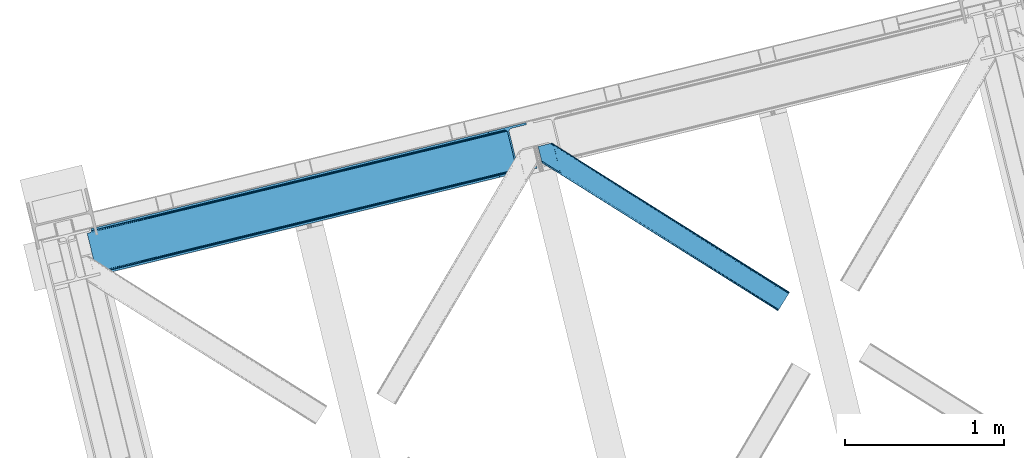
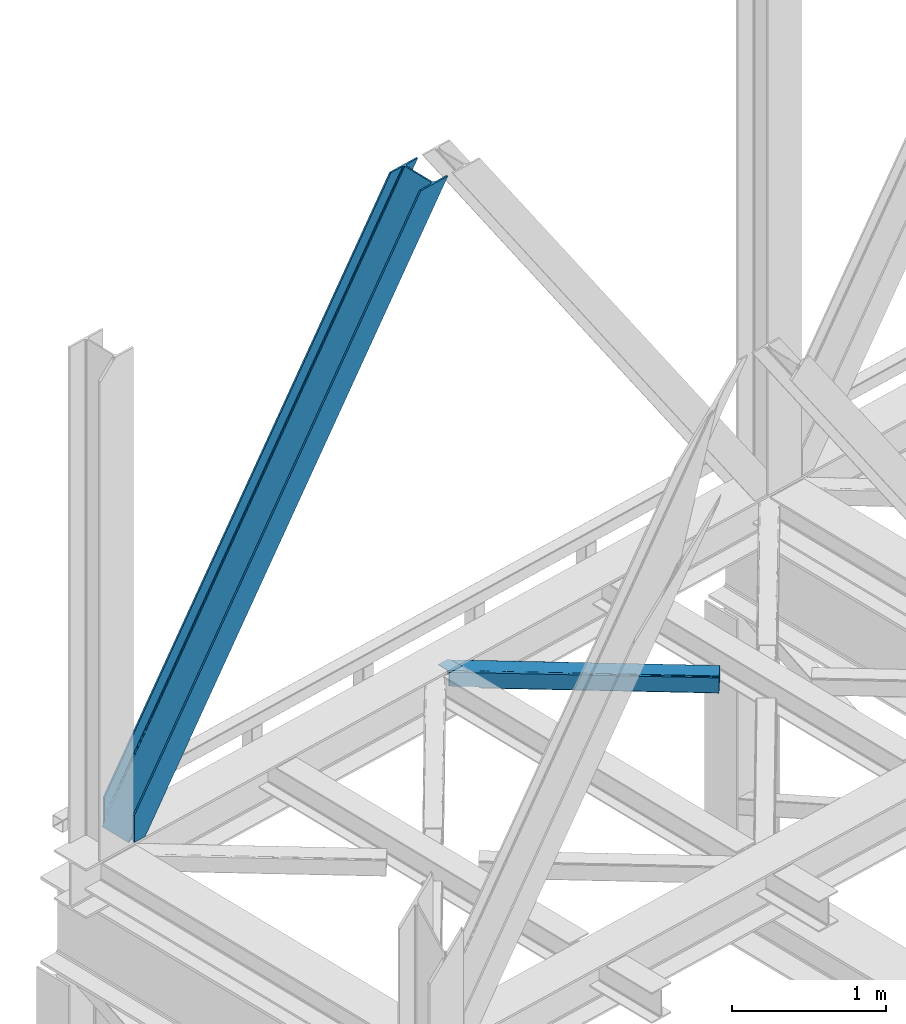
# One storey, part 26 of 93: 2 members.
"""IFC4 building model written with IfcOpenShell, lengths in millimetres."""

from ifc_helpers import new_model, entity, si_unit, converted_unit, derived_unit, direction, frame, origin, place, context, subcontext, project, spatial, triangles, type_object, element, save


model = new_model("IFC4")

# Units and contexts
model_context = context("Model", 3, precision=0.01, world=origin(), true_north=direction((6.12303176911189e-17, 1.0)))
plan_context = context("Plan", 3, precision=0.01, world=origin(), true_north=direction((6.12303176911189e-17, 1.0)))
body_context = subcontext(model_context, "Body", "Model", "MODEL_VIEW")
ifc_project = project(units=[si_unit("LENGTHUNIT", "METRE", prefix="MILLI"), si_unit("AREAUNIT", "SQUARE_METRE"), si_unit("VOLUMEUNIT", "CUBIC_METRE"), converted_unit("PLANEANGLEUNIT", "DEGREE", entity("IfcRatioMeasure", 0.0174532925199433), si_unit("PLANEANGLEUNIT", "RADIAN"), dimensions=[0, 0, 0, 0, 0, 0, 0]), si_unit("MASSUNIT", "GRAM", prefix="KILO"), derived_unit("MASSDENSITYUNIT", [(si_unit("MASSUNIT", "GRAM", prefix="KILO"), 1), (si_unit("LENGTHUNIT", "METRE"), -3)]), derived_unit("MOMENTOFINERTIAUNIT", [(si_unit("LENGTHUNIT", "METRE"), 4)]), si_unit("TIMEUNIT", "SECOND"), si_unit("FREQUENCYUNIT", "HERTZ"), si_unit("THERMODYNAMICTEMPERATUREUNIT", "DEGREE_CELSIUS"), derived_unit("THERMALTRANSMITTANCEUNIT", [(si_unit("MASSUNIT", "GRAM", prefix="KILO"), 1), (si_unit("THERMODYNAMICTEMPERATUREUNIT", "KELVIN"), -1), (si_unit("TIMEUNIT", "SECOND"), -3)]), derived_unit("VOLUMETRICFLOWRATEUNIT", [(si_unit("LENGTHUNIT", "METRE"), 3), (si_unit("TIMEUNIT", "SECOND"), -1)]), derived_unit("MASSFLOWRATEUNIT", [(si_unit("MASSUNIT", "GRAM", prefix="KILO"), 1), (si_unit("TIMEUNIT", "SECOND"), -1)]), derived_unit("ROTATIONALFREQUENCYUNIT", [(si_unit("TIMEUNIT", "SECOND"), -1)]), si_unit("ELECTRICCURRENTUNIT", "AMPERE"), si_unit("ELECTRICVOLTAGEUNIT", "VOLT"), si_unit("POWERUNIT", "WATT"), si_unit("FORCEUNIT", "NEWTON", prefix="KILO"), si_unit("ILLUMINANCEUNIT", "LUX"), si_unit("LUMINOUSFLUXUNIT", "LUMEN"), si_unit("LUMINOUSINTENSITYUNIT", "CANDELA"), derived_unit("USERDEFINED", [(si_unit("MASSUNIT", "GRAM", prefix="KILO"), -1), (si_unit("LENGTHUNIT", "METRE"), -2), (si_unit("TIMEUNIT", "SECOND"), 3), (si_unit("LUMINOUSFLUXUNIT", "LUMEN"), 1)]), derived_unit("LINEARVELOCITYUNIT", [(si_unit("LENGTHUNIT", "METRE"), 1), (si_unit("TIMEUNIT", "SECOND"), -1)]), si_unit("PRESSUREUNIT", "PASCAL"), derived_unit("USERDEFINED", [(si_unit("LENGTHUNIT", "METRE"), -2), (si_unit("MASSUNIT", "GRAM", prefix="KILO"), 1), (si_unit("TIMEUNIT", "SECOND"), -2)]), derived_unit("LINEARFORCEUNIT", [(si_unit("MASSUNIT", "GRAM", prefix="KILO"), 1), (si_unit("LENGTHUNIT", "METRE"), 1), (si_unit("TIMEUNIT", "SECOND"), -2), (si_unit("LENGTHUNIT", "METRE"), -1)]), derived_unit("PLANARFORCEUNIT", [(si_unit("MASSUNIT", "GRAM", prefix="KILO"), 1), (si_unit("LENGTHUNIT", "METRE"), 1), (si_unit("TIMEUNIT", "SECOND"), -2), (si_unit("LENGTHUNIT", "METRE"), -2)])], contexts=[model_context, plan_context])

# Site, building, storey
site_placement = place(None, origin())
site = spatial("IfcSite", under=ifc_project, at=site_placement, CompositionType="ELEMENT")
building_placement = place(site_placement, origin())
building = spatial("IfcBuilding", under=site, at=building_placement, CompositionType="ELEMENT")
storey_placement = place(building_placement, frame((0.0, 0.0, 15900.0)))
storey = spatial("IfcBuildingStorey", under=building, at=storey_placement, CompositionType="ELEMENT", Elevation=15900.0)

# Members
member_type_1 = type_object("IfcMemberType", PredefinedType="BRACE")
member_1_placement = place(storey_placement, frame((-60913.7237548828, 5815.15086364746, 3684.99990234375)))
element("IfcMember", 1, at=member_1_placement, inside=storey, type_object=member_type_1, ObjectType="Steel Vertical Brace", PredefinedType="BRACE", context=body_context, shape_type="Tessellation", body=[
    triangles([(58.5685180664004, 23.1980026245119, 0.0), (60.4660766601519, 15.4258026123052, 0.0), (59.1080200195283, 16.2391250610353, 0.781347656247817), (58.9684936523408, 15.0607086181644, 1.0697021484375), (78.1673217773423, 19.7406555175785, 8.06229858398365), (78.1673217773423, 19.7406555175785, 29.5563354492188), (72.7350952148408, 18.4163177490236, 0.0), (500.415966796871, 117.80269317627, 660.427130126951), (82.4554321289033, 19.9237838745121, 36.4024291992173), (86.4830932617188, 18.4523620605469, 44.3670593261704), (502.150744628903, 124.235440063477, 658.201684570311), (88.0643920898438, 17.2873168945316, 48.5435485839844), (2700.97932128906, 660.223072814942, 3921.00020141601), (2700.96536865235, 667.310430908204, 3921.00020141601), (2273.77749023437, 563.178996276855, 3287.10633544922), (2274.31699218749, 556.220118713379, 3287.88535766601), (2697.74696044921, 653.425231933594, 3921.00020141601), (2272.58686523437, 549.787371826172, 3290.11080322265), (2691.76593017578, 647.951147460938, 3921.00020141601), (2268.84755859375, 544.859765625, 3293.43850708008), (2683.94780273437, 644.634489440919, 3921.00020141601), (2263.67113037109, 542.188417053223, 3297.36384887695), (491.5048828125, 110.20373840332, 667.68017578125), (496.68131103515, 112.875086975097, 663.754833984374), (91.1758300781221, 12.6195785522459, 73.6396911621086), (90.6456298828125, 13.899732971192, 61.2474243164033), (89.48291015625, 15.4258026123052, 55.5245178222649), (501.611242675775, 131.194317626953, 657.42033691406), (945.193469238278, 232.231755065918, 1315.62202148437), (944.65396728515, 239.190632629395, 1314.84299926758), (1388.23154296874, 340.227488708496, 1973.04468383789), (1387.69669189453, 347.186366271972, 1972.26333618164), (1831.27426757812, 448.223803710937, 2630.46502075195), (1830.7394165039, 455.182681274414, 2629.6836730957), (943.458691406246, 225.799008178711, 1317.84746704101), (1386.50141601562, 333.795323181153, 1975.26780395508), (1829.544140625, 441.79105682373, 2632.68814086914), (939.724035644525, 220.871401977539, 1321.17517089844), (1382.762109375, 328.86771697998, 1978.5955078125), (1825.80483398437, 436.864031982422, 2636.01817016601), (934.547607421875, 218.200053405762, 1325.10051269531), (1377.59033203125, 326.196368408203, 1982.52317504883), (1820.63305664063, 434.192102050782, 2639.94351196289), (91.1758300781221, 12.6195785522459, 210.054620361327), (2592.01387939453, 622.225392150879, 3921.00020141601), (1332.51401367187, 573.558013916016, 1972.26333618164), (2645.78734130859, 893.682078552246, 3921.00020141601), (2218.59946289062, 789.550643920898, 3287.10633544922), (1775.55673828124, 681.554328918457, 2629.6836730957), (889.471289062494, 465.562280273438, 1314.84299926758), (446.433215332028, 357.565965270996, 657.42033691406), (3.39049072265334, 249.569650268555, 0.0), (86.4830932617188, 18.4523620605469, 15.6757873535134), (82.4554321289033, 19.9237838745121, 13.352673339843), (84.3483398437456, 19.4546264648443, 14.892114257811), (88.0643920898438, 17.2873168945316, 15.1293090820291), (91.4595336914063, 11.6585906982427, 0.0), (90.6456298828125, 13.899732971192, 7.3414123535149), (89.6456909179688, 15.5502136230471, 12.4201721191384), (91.4595336914063, 11.6585906982427, 210.119732666015), (91.1153686523394, 12.7904983520511, 0.0), (2595.09276123047, 609.595349121094, 3921.00020141601), (94.3012207031206, 0.0, 210.119732666015), (94.3012207031206, 0.0, 0.0), (189.179150390621, 23.1270767211918, 0.0), (2831.57600097656, 667.239505004883, 3921.00020141601), (94.1663452148423, 13.3486038208011, 0.0), (186.100268554685, 35.7577011108397, 0.0), (2828.49711914062, 679.870129394531, 3921.00020141601), (1411.90916748047, 334.561555480957, 1955.37134399414), (2305.60810546875, 552.41104888916, 3281.5159790039), (1858.76096191406, 443.486302185059, 2618.4424987793), (2736.56319580078, 657.460450744629, 3921.00020141601), (965.057373046875, 225.637390136719, 1292.29786376953), (518.205578613277, 116.712643432617, 629.226708984374), (512.382678222653, 116.703341674805, 633.152050781249), (72.1351318359375, 19.4703231811527, 0.0), (502.299572753902, 124.272065734864, 638.705200195313), (506.796972656244, 119.357830810547, 636.479754638669), (499.574157714844, 130.697836303711, 639.484222412109), (2728.0939453125, 656.806420898438, 3921.00020141601), (2299.78520507812, 552.401165771485, 3285.44132080078), (2720.26651611328, 658.914431762695, 3921.00020141601), (2294.19949951171, 555.05623626709, 3288.7690246582), (2714.26688232422, 663.462991333008, 3921.00020141601), (2289.70209960937, 559.969889831543, 3290.99447021484), (2711.01591796875, 669.76028137207, 3921.00020141601), (2286.97668457031, 566.395660400391, 3291.77349243164), (68.6190673828096, 25.6478530883787, 0.0), (959.234472656244, 225.628088378907, 1296.22320556641), (1406.08626708984, 334.552253723145, 1959.29668579101), (1852.93341064453, 443.477000427246, 2622.37016601562), (953.648767089842, 228.282577514648, 1299.55323486328), (1400.50056152343, 337.20732421875, 1962.62438964844), (1847.34770507812, 446.131489562988, 2625.69786987305), (949.1513671875, 233.196812438965, 1301.77635498047), (1396.00316162109, 342.120977783204, 1964.84983520508), (1842.85030517578, 451.045724487305, 2627.92098999023), (946.425952148435, 239.622583007813, 1302.55770263672), (1393.27774658203, 348.546748352051, 1965.62885742187), (1840.12489013671, 457.471495056153, 2628.70233764648), (1784.94686279297, 683.843142700195, 2628.70233764648), (1338.09506835937, 574.918395996094, 1965.62885742187), (2655.837890625, 896.131929016114, 3921.00020141601), (2231.79865722656, 792.767308044434, 3291.77349243164), (891.243273925778, 465.994230651856, 1302.55770263672), (444.396130371089, 357.069483947754, 639.484222412109), (13.4410400390625, 252.019500732422, 0.0), (1.49293212890188, 257.342431640625, 0.0), (13.7154418945283, 259.120811462402, 0.0), (13.7619506835908, 260.332946777344, 0.0), (0.665075683587929, 255.996002197266, 0.781347656247817), (0.0, 256.977337646485, 1.0697021484375), (19.1941772460923, 261.656703186035, 8.06229858398365), (19.1941772460923, 261.656703186035, 29.5563354492188), (439.210400390621, 368.90597076416, 660.427130126951), (433.624694824219, 371.560459899903, 663.754833984374), (27.5890136718735, 272.585105895996, 61.2474243164033), (27.4587890624971, 270.661386108399, 54.4989990234353), (443.707800292963, 363.991735839844, 658.201684570311), (23.0869628906221, 263.467639160156, 36.4024291992173), (26.5565185546875, 268.183049011231, 48.2714721679658), (25.9891113281192, 266.62907409668, 44.3670593261704), (427.797143554686, 371.55115814209, 667.68017578125), (27.4680908203081, 273.966998291015, 73.6396911621086), (2628.70931396484, 906.635939025879, 3921.00020141601), (2620.24006347656, 905.981909179688, 3921.00020141601), (2205.79094238281, 803.545138549805, 3293.43850708008), (2199.96804199219, 803.535836791993, 3297.36384887695), (2636.53674316406, 904.528509521485, 3921.00020141601), (2211.37664794922, 800.890649414063, 3290.11080322265), (2642.53637695313, 899.979949951172, 3921.00020141601), (2215.87404785156, 795.976414489746, 3287.88535766601), (876.662768554685, 479.556774902344, 1321.17517089844), (870.839868164061, 479.547473144531, 1325.10051269531), (1319.70549316406, 587.552508544922, 1978.5955078125), (1313.88259277344, 587.543788146972, 1982.52317504883), (1762.74821777343, 695.548823547363, 2636.01817016601), (1756.92531738281, 695.539521789551, 2639.94351196289), (882.248474121094, 476.902285766601, 1317.84746704101), (1325.29119873047, 584.89801940918, 1975.26780395508), (1768.33392333984, 692.894334411621, 2632.68814086914), (886.750524902338, 471.988050842286, 1315.62202148437), (1329.78859863281, 579.984365844727, 1973.04468383789), (1772.83132324219, 687.980099487305, 2630.46502075195), (2528.31079101563, 883.572811889649, 3921.00020141601), (27.4680908203081, 273.966998291015, 210.054620361327), (449.326062011714, 375.38871459961, 633.152050781249), (445.591406249994, 370.461108398437, 636.479754638669), (26.8541748046846, 268.390594482422, 15.1293090820291), (27.4587890624971, 270.661386108399, 12.4201721191384), (454.502490234372, 378.060063171387, 629.226708984374), (27.5890136718735, 272.585105895996, 7.3414123535149), (30.4586059570283, 274.695442199707, 0.0), (443.856628417969, 364.02836151123, 638.705200195313), (25.9891113281192, 266.62907409668, 15.6757873535134), (23.0869628906221, 263.467639160156, 13.352673339843), (24.556640625, 264.76000213623, 14.8944396972656), (2655.82393798828, 903.219287109375, 3921.00020141601), (2231.25915527344, 799.726766967774, 3290.99447021484), (2659.05629882812, 910.017127990723, 3921.00020141601), (2232.98928222656, 806.159513854981, 3288.7690246582), (2665.03732910156, 915.491212463379, 3921.00020141601), (2236.72858886718, 811.08653869629, 3285.44132080078), (2672.85545654297, 918.807870483399, 3921.00020141601), (2241.90501708984, 813.757887268067, 3281.5159790039), (27.4959960937485, 273.787358093262, 0.0), (890.70842285156, 472.953108215333, 1301.77635498047), (1337.56021728515, 581.877854919434, 1964.84983520508), (1784.40736083984, 690.802020263672, 2627.92098999023), (892.438549804683, 479.38585510254, 1299.55323486328), (1339.29034423828, 588.310020446777, 1962.62438964844), (1786.14213867187, 697.234767150879, 2625.69786987305), (896.177856445313, 484.312879943848, 1296.22320556641), (1343.0296508789, 593.23762664795, 1959.29668579101), (1789.87679443359, 702.161791992187, 2622.37016601562), (901.349633789061, 486.984809875488, 1292.29786376953), (1348.20142822265, 595.908975219727, 1955.37134399414), (1795.05322265625, 704.833721923828, 2618.4424987793), (27.2774047851563, 274.948915100098, 0.0), (27.2774047851563, 274.948915100098, 210.119732666015), (2525.23190917969, 896.202854919434, 3921.00020141601), (24.4357177734346, 286.60750579834, 210.119732666015), (24.4357177734346, 286.60750579834, 0.0), (2761.71049804687, 953.847592163086, 3921.00020141601), (2764.78937988281, 941.216967773437, 3921.00020141601), (119.313647460935, 309.735163879394, 0.0), (122.392529296871, 297.105120849609, 0.0)], [[1, 2, 3], [4, 3, 2], [5, 4, 2], [4, 5, 6], [2, 7, 5], [8, 9, 10], [11, 3, 6], [6, 8, 11], [6, 9, 8], [3, 4, 6], [10, 12, 8], [13, 14, 15], [15, 16, 13], [17, 13, 16], [16, 18, 17], [19, 17, 18], [18, 20, 19], [21, 19, 20], [20, 22, 21], [23, 24, 25], [26, 25, 24], [26, 8, 27], [26, 24, 8], [12, 27, 8], [11, 28, 3], [1, 3, 28], [29, 30, 28], [28, 11, 29], [31, 32, 30], [30, 29, 31], [33, 34, 32], [32, 31, 33], [16, 15, 34], [34, 33, 16], [35, 29, 11], [11, 8, 35], [36, 31, 29], [29, 35, 36], [37, 33, 31], [31, 36, 37], [18, 16, 33], [33, 37, 18], [38, 35, 24], [8, 24, 35], [39, 36, 38], [35, 38, 36], [40, 37, 39], [36, 39, 37], [20, 18, 40], [37, 40, 18], [41, 38, 24], [24, 23, 41], [42, 39, 38], [38, 41, 42], [43, 40, 39], [39, 42, 43], [22, 20, 43], [40, 43, 20], [42, 44, 45], [45, 22, 43], [22, 45, 21], [43, 42, 45], [44, 42, 41], [41, 23, 44], [25, 44, 23], [34, 46, 32], [14, 47, 48], [49, 15, 48], [46, 34, 49], [48, 15, 14], [49, 34, 15], [32, 50, 30], [50, 51, 28], [50, 32, 46], [52, 1, 51], [50, 28, 30], [51, 1, 28], [53, 10, 9], [9, 54, 55], [56, 27, 12], [56, 12, 10], [10, 53, 56], [57, 26, 58], [58, 26, 27], [27, 59, 58], [57, 60, 25], [44, 25, 60], [25, 26, 57], [58, 61, 57], [56, 59, 27], [9, 55, 53], [54, 9, 6], [6, 5, 54], [62, 60, 63], [62, 45, 60], [44, 60, 45], [64, 63, 60], [60, 57, 64], [62, 65, 66], [65, 62, 63], [64, 65, 63], [65, 67, 64], [67, 65, 68], [61, 57, 67], [57, 64, 67], [69, 66, 68], [65, 68, 66], [70, 69, 68], [71, 69, 72], [71, 73, 69], [70, 72, 69], [68, 74, 70], [75, 74, 68], [68, 67, 75], [76, 59, 56], [76, 58, 59], [77, 78, 5], [78, 55, 54], [78, 53, 55], [54, 5, 78], [5, 7, 77], [78, 79, 56], [56, 53, 78], [80, 78, 77], [67, 61, 58], [76, 75, 58], [67, 58, 75], [81, 73, 71], [71, 82, 81], [83, 81, 82], [82, 84, 83], [85, 83, 84], [84, 86, 85], [87, 85, 86], [86, 88, 87], [77, 89, 80], [56, 79, 76], [90, 74, 76], [75, 76, 74], [91, 70, 90], [74, 90, 70], [92, 72, 91], [70, 91, 72], [82, 71, 92], [72, 92, 71], [93, 90, 76], [76, 79, 93], [94, 91, 90], [90, 93, 94], [95, 92, 91], [91, 94, 95], [84, 82, 92], [92, 95, 84], [96, 93, 78], [79, 78, 93], [97, 94, 93], [93, 96, 97], [98, 95, 94], [94, 97, 98], [86, 84, 95], [95, 98, 86], [99, 96, 80], [78, 80, 96], [100, 97, 99], [96, 99, 97], [101, 98, 100], [97, 100, 98], [88, 86, 101], [98, 101, 86], [102, 100, 103], [104, 87, 88], [101, 105, 88], [100, 102, 101], [88, 105, 104], [101, 102, 105], [103, 99, 106], [99, 80, 107], [99, 103, 100], [89, 108, 80], [99, 107, 106], [80, 108, 107], [109, 108, 110], [1, 89, 108], [1, 108, 52], [1, 2, 89], [109, 52, 108], [7, 77, 2], [77, 89, 2], [110, 111, 109], [109, 52, 112], [112, 113, 109], [113, 114, 109], [113, 115, 114], [111, 109, 114], [116, 117, 118], [118, 119, 116], [120, 121, 115], [115, 112, 120], [115, 113, 112], [120, 116, 122], [122, 123, 120], [123, 121, 120], [119, 122, 116], [117, 124, 125], [125, 118, 117], [126, 127, 128], [129, 128, 127], [130, 126, 131], [128, 131, 126], [132, 130, 133], [131, 133, 130], [47, 132, 48], [133, 48, 132], [134, 135, 124], [124, 117, 134], [136, 137, 134], [135, 134, 137], [138, 139, 136], [137, 136, 139], [128, 129, 139], [139, 138, 128], [140, 134, 117], [117, 116, 140], [141, 136, 134], [134, 140, 141], [142, 138, 136], [136, 141, 142], [131, 128, 138], [138, 142, 131], [143, 140, 120], [116, 120, 140], [144, 141, 143], [140, 143, 141], [145, 142, 144], [141, 144, 142], [133, 131, 145], [142, 145, 131], [51, 120, 112], [112, 52, 51], [50, 143, 51], [120, 51, 143], [46, 144, 50], [143, 50, 144], [49, 145, 46], [144, 46, 145], [48, 133, 49], [145, 49, 133], [146, 147, 137], [137, 139, 146], [139, 129, 146], [127, 146, 129], [135, 137, 147], [147, 125, 124], [124, 135, 147], [148, 149, 150], [150, 151, 148], [152, 148, 153], [153, 154, 152], [107, 108, 110], [155, 156, 150], [155, 110, 114], [114, 157, 155], [157, 158, 155], [158, 156, 155], [110, 111, 114], [150, 149, 155], [110, 155, 107], [159, 104, 160], [105, 160, 104], [161, 159, 162], [160, 162, 159], [163, 161, 164], [162, 164, 161], [165, 163, 166], [164, 166, 163], [153, 167, 154], [151, 153, 148], [168, 106, 107], [107, 155, 168], [169, 103, 106], [106, 168, 169], [170, 102, 103], [103, 169, 170], [160, 105, 102], [102, 170, 160], [171, 168, 155], [155, 149, 171], [172, 169, 171], [168, 171, 169], [173, 170, 172], [169, 172, 170], [162, 160, 173], [170, 173, 160], [174, 171, 148], [149, 148, 171], [175, 172, 174], [171, 174, 172], [176, 173, 175], [172, 175, 173], [164, 162, 176], [173, 176, 162], [177, 174, 148], [148, 152, 177], [178, 175, 174], [174, 177, 178], [179, 176, 175], [175, 178, 179], [166, 164, 176], [176, 179, 166], [156, 158, 121], [121, 123, 156], [150, 156, 123], [123, 122, 150], [119, 151, 150], [118, 153, 119], [151, 119, 153], [180, 167, 153], [153, 125, 180], [181, 180, 125], [125, 147, 181], [118, 125, 153], [122, 119, 150], [158, 157, 121], [121, 157, 115], [114, 115, 157], [182, 181, 146], [181, 182, 183], [181, 147, 146], [180, 181, 184], [183, 184, 181], [47, 14, 104], [17, 19, 81], [21, 62, 66], [45, 62, 21], [19, 21, 73], [14, 13, 85], [13, 17, 83], [130, 163, 126], [182, 127, 185], [127, 126, 165], [182, 146, 127], [130, 132, 161], [132, 47, 159], [104, 14, 87], [73, 81, 19], [85, 13, 83], [81, 83, 17], [85, 87, 14], [66, 73, 21], [66, 69, 73], [165, 126, 163], [161, 132, 159], [104, 159, 47], [161, 163, 130], [165, 185, 127], [185, 165, 186], [187, 154, 184], [154, 187, 188], [167, 180, 154], [180, 184, 154], [182, 187, 183], [182, 185, 187], [187, 184, 183], [186, 178, 188], [179, 186, 166], [186, 179, 178], [186, 165, 166], [177, 188, 178], [154, 188, 152], [177, 152, 188], [185, 186, 187], [188, 187, 186]]),
])
member_type_2 = type_object("IfcMemberType", PredefinedType="BRACE")
member_2_placement = place(storey_placement, frame((-58076.8457519531, 5584.42250518799, 3511.0000579834)))
element("IfcMember", 2, at=member_2_placement, inside=storey, type_object=member_type_2, ObjectType="Steel Horizontal Brace", PredefinedType="BRACE", context=body_context, shape_type="Tessellation", body=[
    triangles([(207.717553710943, 837.213432312012, 0.0), (172.040661621097, 983.576010131836, 0.0), (1573.7830078125, 103.755294799805, 0.0), (1517.96315917969, 14.8223510742191, 0.0), (1583.08941650391, 118.577645874024, 17.5000946044929), (1582.37783203126, 117.449226379395, 10.8028289794929), (166.547973632813, 1006.1130065918, 10.8028289794929), (166.096838378908, 1007.96986999512, 17.5000946044929), (1580.36400146485, 114.236631774902, 5.12526855468968), (167.83626708985, 1000.82495727539, 5.12526855468968), (1577.34558105469, 109.42762298584, 1.33247680664135), (169.766381835943, 992.910905456543, 1.33247680664135), (1514.40523681641, 9.15002288818323, 1.33247680664135), (202.587634277348, 832.527671813965, 1.33247680664135), (208.508203125006, 833.971769714355, 0.155804443362285), (1511.38681640625, 4.34159545898456, 5.12526855468968), (194.895080566406, 830.652786254883, 5.12526855468968), (1509.36833496094, 1.12841949462927, 10.8028289794929), (189.755859375, 829.399955749512, 10.8028289794929), (1508.66140136719, 0.0, 17.5000946044929), (187.951318359381, 828.959866333008, 17.5000946044929), (204.378222656254, 832.964854431152, 12.1260040283232), (208.508203125006, 833.971769714355, 9.69243164062573), (199.652929687501, 831.812017822265, 17.9802978515654), (198.425097656254, 831.512617492675, 19.4999725341804), (187.951318359381, 828.959866333008, 19.4999725341804), (25.3100830078183, 931.043751525879, 19.4999725341804), (22.6823364257871, 941.818675231933, 19.4999725341804), (1508.66140136719, 0.0, 122.500662231447), (25.3100830078183, 931.043751525879, 122.500662231447), (1521.68386230469, 20.7510589599606, 6.99957275390625), (205.340954589847, 846.970976257324, 6.99957275390625), (207.559423828126, 837.873275756836, 8.88434143066479), (1518.12593994141, 15.0787307739256, 8.3320495605476), (1515.10751953125, 10.2703033447269, 12.1260040283232), (1513.08903808594, 7.05712738037073, 17.8035644531265), (1512.38210449219, 5.92870788574237, 24.4996673583992), (22.9288330078125, 940.801295471191, 24.4996673583992), (174.421911621095, 973.818466186523, 6.99957275390625), (1570.0623046875, 97.8265869140623, 6.99957275390625), (168.971081542972, 996.182798767089, 17.8803039550803), (170.217517089848, 991.067413330078, 12.1260040283232), (172.142980957033, 983.15336151123, 8.3320495605476), (168.836206054693, 996.73392791748, 18.5000335693367), (166.096838378908, 1007.96986999512, 18.5000335693367), (1512.38210449219, 5.92870788574237, 115.501089477541), (22.9288330078125, 940.801295471191, 115.501089477541), (1521.68386230469, 20.7510589599606, 133.000021362306), (1518.12593994141, 15.0787307739256, 131.667544555665), (19.2592895507842, 955.860260009766, 131.667544555665), (16.9850097656308, 965.195155334472, 133.000021362306), (1515.10751953125, 10.2703033447269, 127.87475280762), (21.1894042968779, 947.946208190918, 127.87475280762), (1513.08903808594, 7.05712738037073, 122.196029663086), (22.4776977539077, 942.658158874512, 122.196029663086), (168.515295410158, 997.028096008301, 18.7407165527366), (165.808483886722, 1008.15009155273, 18.736065673831), (168.171130371098, 997.346099853516, 19.0000030517585), (165.487573242193, 1008.35124206543, 19.0000030517585), (167.826965332031, 997.66410369873, 19.2592895507842), (165.166662597658, 1008.55181121826, 19.2639404296897), (167.506054687503, 997.958271789551, 19.4999725341804), (164.878308105472, 1008.73261413574, 19.4999725341804), (78.2928955078169, 1053.95369110107, 19.4999725341804), (88.7666748046904, 1056.50644226074, 19.4999725341804), (24.8542968750044, 932.900614929199, 129.197927856447), (23.5660034179746, 938.188664245606, 134.874325561526), (22.1242309570371, 944.113883972168, 137.999716186525), (0.0, 1034.86880950928, 137.999716186525), (0.0, 1034.86880950928, 133.000021362306), (1583.08941650391, 118.577645874024, 122.500662231447), (88.7666748046904, 1056.50644226074, 122.500662231447), (1578.65712890626, 111.520518493652, 17.8035644531265), (1579.36871337891, 112.648937988281, 24.4996673583992), (79.2835327148496, 1054.19495544434, 24.4996673583992), (1573.62487792969, 103.498915100097, 8.3320495605476), (1576.64329833985, 108.307342529297, 12.1260040283232), (64.647216796875, 1050.62714996338, 131.667544555665), (55.5733520507856, 1048.41507568359, 133.000021362306), (76.0651245117188, 1053.41011962891, 137.999716186525), (81.8229125976577, 1054.81352233887, 134.874325561526), (72.3397705078169, 1052.50203552246, 127.87475280762), (77.4789916992231, 1053.75486602783, 122.196029663086), (86.962133789064, 1056.06635284424, 129.197927856447), (79.2835327148496, 1054.19495544434, 115.501089477541), (1570.0623046875, 97.8265869140623, 133.000021362306), (1579.36871337891, 112.648937988281, 115.501089477541), (1578.65712890626, 111.520518493652, 122.196029663086), (1576.64329833985, 108.307342529297, 127.87475280762), (1573.62487792969, 103.498915100097, 131.667544555665), (1582.37783203126, 117.449226379395, 129.197927856447), (1580.36400146485, 114.236631774902, 134.874325561526), (1577.34558105469, 109.42762298584, 138.667117309571), (1573.7830078125, 103.755294799805, 139.999594116212), (1517.96315917969, 14.8223510742191, 139.999594116212), (1514.40523681641, 9.15002288818323, 138.667117309571), (1511.38681640625, 4.34159545898456, 134.874325561526), (1509.36833496094, 1.12841949462927, 129.197927856447), (98.1940063476577, 1039.52085113525, 137.999716186525), (139.391491699222, 870.509074401855, 137.999716186525), (137.847399902348, 881.070639038086, 139.999594116212), (139.828674316406, 872.942646789551, 138.999655151369), (140.051916503908, 871.778764343262, 138.667117309571), (139.805419921875, 870.421870422363, 138.076455688479), (139.921691894531, 871.056134033203, 138.353182983399), (98.7056030273452, 1039.02378845215, 138.076455688479), (99.5985717773438, 1036.93496246338, 138.634561157229), (99.1985961914106, 1037.87211456299, 138.383413696291), (100.184582519534, 1035.56120910644, 138.999655151369), (102.1658569336, 1027.43379821777, 139.999594116212), (140.037963867188, 871.692723083496, 138.629910278323)], [[1, 2, 3], [3, 4, 1], [5, 6, 7], [7, 8, 5], [6, 9, 10], [10, 7, 6], [9, 11, 12], [12, 10, 9], [11, 3, 2], [2, 12, 11], [13, 14, 15], [15, 4, 13], [15, 1, 4], [13, 16, 14], [17, 14, 16], [16, 18, 17], [19, 17, 18], [18, 20, 19], [21, 19, 20], [22, 23, 14], [22, 14, 17], [17, 19, 24], [23, 15, 14], [24, 22, 17], [19, 21, 25], [26, 25, 21], [19, 25, 24], [27, 28, 25], [25, 26, 27], [26, 29, 30], [20, 26, 21], [26, 20, 29], [26, 30, 27], [31, 32, 33], [34, 33, 23], [23, 35, 34], [23, 22, 35], [36, 35, 22], [37, 36, 24], [24, 25, 37], [37, 25, 38], [28, 38, 25], [22, 24, 36], [33, 34, 31], [39, 32, 40], [31, 40, 32], [41, 7, 10], [10, 42, 41], [12, 42, 10], [42, 12, 43], [7, 44, 8], [45, 8, 44], [7, 41, 44], [43, 12, 2], [33, 32, 1], [1, 39, 2], [39, 1, 32], [15, 33, 1], [39, 43, 2], [23, 33, 15], [46, 37, 38], [38, 47, 46], [48, 49, 50], [50, 51, 48], [49, 52, 53], [53, 50, 49], [52, 54, 55], [55, 53, 52], [54, 46, 47], [47, 55, 54], [45, 44, 56], [56, 57, 45], [57, 56, 58], [58, 59, 57], [59, 58, 60], [60, 61, 59], [61, 60, 62], [62, 63, 61], [64, 65, 63], [63, 62, 64], [47, 27, 30], [66, 55, 30], [55, 66, 67], [55, 47, 30], [38, 27, 47], [28, 27, 38], [53, 55, 67], [68, 51, 50], [51, 68, 69], [69, 70, 51], [50, 53, 68], [68, 53, 67], [5, 45, 71], [8, 45, 5], [45, 72, 71], [72, 45, 57], [72, 57, 59], [59, 61, 72], [63, 72, 61], [72, 63, 65], [73, 41, 42], [74, 75, 62], [62, 73, 74], [56, 73, 58], [56, 44, 73], [73, 60, 58], [73, 62, 60], [44, 41, 73], [75, 64, 62], [40, 76, 39], [43, 39, 76], [76, 77, 43], [42, 43, 77], [42, 77, 73], [78, 79, 80], [81, 82, 80], [78, 80, 82], [83, 81, 84], [79, 69, 80], [79, 70, 69], [83, 82, 81], [72, 85, 83], [85, 72, 65], [75, 65, 64], [65, 75, 85], [72, 83, 84], [51, 79, 86], [79, 51, 70], [86, 48, 51], [74, 87, 85], [85, 75, 74], [87, 88, 85], [83, 85, 88], [88, 89, 83], [82, 83, 89], [89, 90, 82], [78, 82, 90], [90, 86, 78], [79, 78, 86], [91, 89, 88], [87, 5, 71], [91, 88, 71], [91, 92, 89], [88, 87, 71], [89, 92, 93], [86, 94, 95], [94, 90, 93], [90, 94, 86], [90, 89, 93], [6, 77, 9], [74, 5, 87], [5, 73, 6], [73, 5, 74], [6, 73, 77], [3, 40, 4], [11, 9, 77], [77, 76, 11], [76, 40, 3], [3, 11, 76], [52, 96, 97], [95, 48, 86], [95, 49, 48], [49, 95, 96], [52, 49, 96], [46, 29, 20], [98, 54, 52], [97, 98, 52], [54, 98, 29], [46, 54, 29], [13, 35, 16], [4, 40, 31], [31, 34, 4], [34, 35, 13], [13, 4, 34], [18, 16, 35], [20, 37, 46], [36, 20, 18], [20, 36, 37], [36, 18, 35], [80, 68, 99], [80, 69, 68], [100, 99, 68], [95, 101, 102], [102, 96, 95], [102, 103, 96], [97, 104, 100], [100, 67, 97], [100, 68, 67], [96, 105, 104], [96, 103, 105], [104, 97, 96], [29, 98, 30], [66, 30, 98], [98, 97, 66], [67, 66, 97], [92, 81, 106], [106, 93, 92], [107, 93, 108], [106, 108, 93], [81, 80, 99], [107, 94, 93], [107, 109, 94], [109, 110, 94], [92, 91, 84], [84, 81, 92], [91, 71, 72], [72, 84, 91], [110, 101, 94], [95, 94, 101], [111, 102, 109], [109, 107, 111], [107, 108, 104], [108, 106, 104], [110, 109, 101], [102, 101, 109]]),
])

save(model, "model.ifc")
